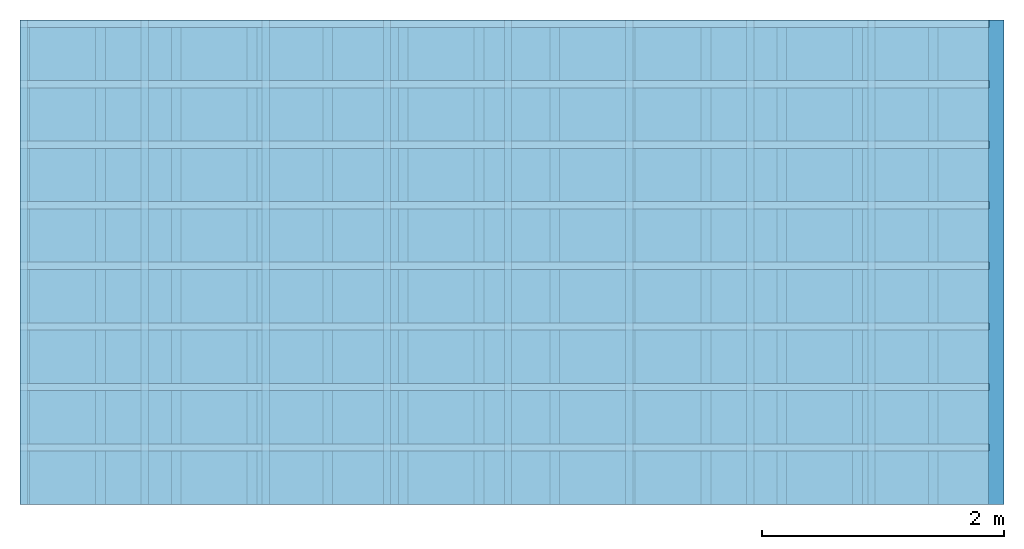
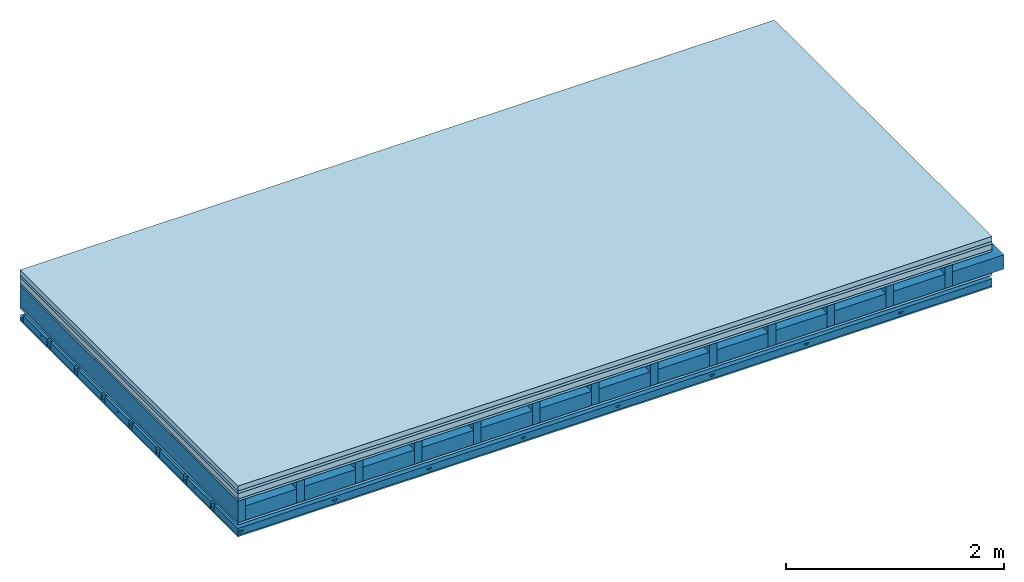
# One storey: 6 plates, 5 members, 1 element without a shape of its own.
"""IFC4 building model written with IfcOpenShell, lengths in metres."""

from ifc_helpers import new_model, si_unit, derived_unit, direction, frame, frame_2d, origin, origin_with_axes, place, context, project, spatial, polyline, rectangle, outline, extrude, material, layer, layer_set, type_object, element, aggregate, save


model = new_model("IFC4")

# Units and contexts
plan_context = context("Plan", 3, precision=1e-05, world=origin(), true_north=direction((0.0, 1.0)))
model_context = context("Model", 3, precision=1e-05, world=origin(), true_north=direction((0.0, 1.0)))
ifc_project = project(units=[si_unit("LENGTHUNIT", "METRE"), derived_unit("SOUNDPRESSUREUNIT", [(si_unit("PRESSUREUNIT", "PASCAL", prefix="MICRO"), 0)]), si_unit("ENERGYUNIT", "JOULE", prefix="MEGA"), si_unit("MASSUNIT", "GRAM", prefix="KILO"), derived_unit("THERMALTRANSMITTANCEUNIT", [(si_unit("POWERUNIT", "WATT"), 1), (si_unit("AREAUNIT", "SQUARE_METRE"), -1), (si_unit("THERMODYNAMICTEMPERATUREUNIT", "KELVIN"), -1)]), derived_unit("AREADENSITYUNIT", [(si_unit("MASSUNIT", "GRAM", prefix="KILO"), 1), (si_unit("AREAUNIT", "SQUARE_METRE"), -1)]), derived_unit("USERDEFINED", [(si_unit("ENERGYUNIT", "JOULE", prefix="MEGA"), 1), (si_unit("AREAUNIT", "SQUARE_METRE"), -1)])], contexts=[plan_context, model_context])

# Site, building, storey
site = spatial("IfcSite", under=ifc_project)
building_placement = place(None, origin())
building = spatial("IfcBuilding", under=site, at=building_placement)
storey_placement = place(building_placement, origin())
storey = spatial("IfcBuildingStorey", under=building, at=storey_placement)

# Slab, members, plates
ifc_material_1 = material(Category="04.005")
ifc_layer_1 = layer(ifc_material_1, 0.055, Name="On-material")
ifc_material_2 = material()
ifc_layer_2 = layer(ifc_material_2, 0.03, Name="Impact sound insulation")
ifc_material_3 = material(Name="Cement panels, glued on sub-floor", Category="02.007")
ifc_layer_3 = layer(ifc_material_3, 0.06, Name="on Supporting structure")
ifc_material_4 = material(Category="07.001")
ifc_layer_4 = layer(ifc_material_4, 0.025, Name="Sub-floor")
ifc_material_5 = material(Name="Rigid, of the art")
ifc_layer_5 = layer(ifc_material_5, 0.0, Name="Bond")
ifc_layer_6 = layer(None, 0.24, Name="Supporting structure")
ifc_layer_7 = layer(ifc_material_5, 0.0, Name="Bond")
ifc_layer_8 = layer(ifc_material_4, 0.025, Name="Lower layer 1")
ifc_layer_9 = layer(None, 0.093, Name="Coupling")
ifc_layer_10 = layer(None, 0.027, Name="Battens / profiles")
ifc_material_6 = material(Name="Plasterboard type A", Category="03.008")
ifc_layer_11 = layer(ifc_material_6, 0.015, Name="Ceiling covering 1st layer")
ifc_material_7 = material(Name="joints", Category="04.017")
ifc_layer_12 = layer(ifc_material_7, 0.0, Name="Surface / treatment")
ifc_layer_set = layer_set([ifc_layer_1, ifc_layer_2, ifc_layer_3, ifc_layer_4, ifc_layer_5, ifc_layer_6, ifc_layer_7, ifc_layer_8, ifc_layer_9, ifc_layer_10, ifc_layer_11, ifc_layer_12])
slab_type = type_object("IfcSlabType", Name="A0525", PredefinedType="NOTDEFINED", material=ifc_layer_set)
slab_placement = place(None, frame((0.0, 0.0, 0.0), z_axis=(0.0, 0.0, -1.0), x_axis=(1.0, 0.0, 0.0)))
slab = element("IfcSlab", 1, at=slab_placement, inside=storey, type_object=slab_type, material=ifc_layer_set, Name="Slab #1")
ifc_material_8 = material()
member_1_placement = place(slab_placement, origin())
member_1 = element("IfcMember", 2, at=member_1_placement, material=ifc_material_8, Name="Supporting structure", context=plan_context, shape_type="SweptSolid", body=[
    extrude(rectangle(XDim=0.08, YDim=0.24, at=frame_2d((0.04, 0.12), x_axis=(1.0, 0.0))), frame((0.0, 4.0, 0.17), z_axis=(0.0, -1.0, 0.0), x_axis=(1.0, 0.0, 0.0)), (0.0, 0.0, 1.0), 4.0),
    extrude(rectangle(XDim=0.08, YDim=0.24, at=frame_2d((0.04, 0.12), x_axis=(1.0, 0.0))), frame((0.625, 4.0, 0.17), z_axis=(0.0, -1.0, 0.0), x_axis=(1.0, 0.0, 0.0)), (0.0, 0.0, 1.0), 4.0),
    extrude(rectangle(XDim=0.08, YDim=0.24, at=frame_2d((0.04, 0.12), x_axis=(1.0, 0.0))), frame((1.25, 4.0, 0.17), z_axis=(0.0, -1.0, 0.0), x_axis=(1.0, 0.0, 0.0)), (0.0, 0.0, 1.0), 4.0),
    extrude(rectangle(XDim=0.08, YDim=0.24, at=frame_2d((0.04, 0.12), x_axis=(1.0, 0.0))), frame((1.875, 4.0, 0.17), z_axis=(0.0, -1.0, 0.0), x_axis=(1.0, 0.0, 0.0)), (0.0, 0.0, 1.0), 4.0),
    extrude(rectangle(XDim=0.08, YDim=0.24, at=frame_2d((0.04, 0.12), x_axis=(1.0, 0.0))), frame((2.5, 4.0, 0.17), z_axis=(0.0, -1.0, 0.0), x_axis=(1.0, 0.0, 0.0)), (0.0, 0.0, 1.0), 4.0),
    extrude(rectangle(XDim=0.08, YDim=0.24, at=frame_2d((0.04, 0.12), x_axis=(1.0, 0.0))), frame((3.125, 4.0, 0.17), z_axis=(0.0, -1.0, 0.0), x_axis=(1.0, 0.0, 0.0)), (0.0, 0.0, 1.0), 4.0),
    extrude(rectangle(XDim=0.08, YDim=0.24, at=frame_2d((0.04, 0.12), x_axis=(1.0, 0.0))), frame((3.75, 4.0, 0.17), z_axis=(0.0, -1.0, 0.0), x_axis=(1.0, 0.0, 0.0)), (0.0, 0.0, 1.0), 4.0),
    extrude(rectangle(XDim=0.08, YDim=0.24, at=frame_2d((0.04, 0.12), x_axis=(1.0, 0.0))), frame((4.375, 4.0, 0.17), z_axis=(0.0, -1.0, 0.0), x_axis=(1.0, 0.0, 0.0)), (0.0, 0.0, 1.0), 4.0),
    extrude(rectangle(XDim=0.08, YDim=0.24, at=frame_2d((0.04, 0.12), x_axis=(1.0, 0.0))), frame((5.0, 4.0, 0.17), z_axis=(0.0, -1.0, 0.0), x_axis=(1.0, 0.0, 0.0)), (0.0, 0.0, 1.0), 4.0),
    extrude(rectangle(XDim=0.08, YDim=0.24, at=frame_2d((0.04, 0.12), x_axis=(1.0, 0.0))), frame((5.625, 4.0, 0.17), z_axis=(0.0, -1.0, 0.0), x_axis=(1.0, 0.0, 0.0)), (0.0, 0.0, 1.0), 4.0),
    extrude(rectangle(XDim=0.08, YDim=0.24, at=frame_2d((0.04, 0.12), x_axis=(1.0, 0.0))), frame((6.25, 4.0, 0.17), z_axis=(0.0, -1.0, 0.0), x_axis=(1.0, 0.0, 0.0)), (0.0, 0.0, 1.0), 4.0),
    extrude(rectangle(XDim=0.08, YDim=0.24, at=frame_2d((0.04, 0.12), x_axis=(1.0, 0.0))), frame((6.875, 4.0, 0.17), z_axis=(0.0, -1.0, 0.0), x_axis=(1.0, 0.0, 0.0)), (0.0, 0.0, 1.0), 4.0),
    extrude(rectangle(XDim=0.08, YDim=0.24, at=frame_2d((0.04, 0.12), x_axis=(1.0, 0.0))), frame((7.5, 4.0, 0.17), z_axis=(0.0, -1.0, 0.0), x_axis=(1.0, 0.0, 0.0)), (0.0, 0.0, 1.0), 4.0),
])
ifc_material_9 = material()
member_2_placement = place(slab_placement, origin())
member_2 = element("IfcMember", 3, at=member_2_placement, material=ifc_material_9, Name="Cavity", context=plan_context, shape_type="SweptSolid", body=[
    extrude(rectangle(XDim=0.545, YDim=0.16, at=frame_2d((0.2725, 0.08), x_axis=(1.0, 0.0))), frame((0.08, 4.0, 0.25), z_axis=(0.0, -1.0, 0.0), x_axis=(1.0, 0.0, 0.0)), (0.0, 0.0, 1.0), 4.0),
    extrude(rectangle(XDim=0.545, YDim=0.16, at=frame_2d((0.2725, 0.08), x_axis=(1.0, 0.0))), frame((0.705, 4.0, 0.25), z_axis=(0.0, -1.0, 0.0), x_axis=(1.0, 0.0, 0.0)), (0.0, 0.0, 1.0), 4.0),
    extrude(rectangle(XDim=0.545, YDim=0.16, at=frame_2d((0.2725, 0.08), x_axis=(1.0, 0.0))), frame((1.33, 4.0, 0.25), z_axis=(0.0, -1.0, 0.0), x_axis=(1.0, 0.0, 0.0)), (0.0, 0.0, 1.0), 4.0),
    extrude(rectangle(XDim=0.545, YDim=0.16, at=frame_2d((0.2725, 0.08), x_axis=(1.0, 0.0))), frame((1.955, 4.0, 0.25), z_axis=(0.0, -1.0, 0.0), x_axis=(1.0, 0.0, 0.0)), (0.0, 0.0, 1.0), 4.0),
    extrude(rectangle(XDim=0.545, YDim=0.16, at=frame_2d((0.2725, 0.08), x_axis=(1.0, 0.0))), frame((2.58, 4.0, 0.25), z_axis=(0.0, -1.0, 0.0), x_axis=(1.0, 0.0, 0.0)), (0.0, 0.0, 1.0), 4.0),
    extrude(rectangle(XDim=0.545, YDim=0.16, at=frame_2d((0.2725, 0.08), x_axis=(1.0, 0.0))), frame((3.205, 4.0, 0.25), z_axis=(0.0, -1.0, 0.0), x_axis=(1.0, 0.0, 0.0)), (0.0, 0.0, 1.0), 4.0),
    extrude(rectangle(XDim=0.545, YDim=0.16, at=frame_2d((0.2725, 0.08), x_axis=(1.0, 0.0))), frame((3.83, 4.0, 0.25), z_axis=(0.0, -1.0, 0.0), x_axis=(1.0, 0.0, 0.0)), (0.0, 0.0, 1.0), 4.0),
    extrude(rectangle(XDim=0.545, YDim=0.16, at=frame_2d((0.2725, 0.08), x_axis=(1.0, 0.0))), frame((4.455, 4.0, 0.25), z_axis=(0.0, -1.0, 0.0), x_axis=(1.0, 0.0, 0.0)), (0.0, 0.0, 1.0), 4.0),
    extrude(rectangle(XDim=0.545, YDim=0.16, at=frame_2d((0.2725, 0.08), x_axis=(1.0, 0.0))), frame((5.08, 4.0, 0.25), z_axis=(0.0, -1.0, 0.0), x_axis=(1.0, 0.0, 0.0)), (0.0, 0.0, 1.0), 4.0),
    extrude(rectangle(XDim=0.545, YDim=0.16, at=frame_2d((0.2725, 0.08), x_axis=(1.0, 0.0))), frame((5.705, 4.0, 0.25), z_axis=(0.0, -1.0, 0.0), x_axis=(1.0, 0.0, 0.0)), (0.0, 0.0, 1.0), 4.0),
    extrude(rectangle(XDim=0.545, YDim=0.16, at=frame_2d((0.2725, 0.08), x_axis=(1.0, 0.0))), frame((6.33, 4.0, 0.25), z_axis=(0.0, -1.0, 0.0), x_axis=(1.0, 0.0, 0.0)), (0.0, 0.0, 1.0), 4.0),
    extrude(rectangle(XDim=0.545, YDim=0.16, at=frame_2d((0.2725, 0.08), x_axis=(1.0, 0.0))), frame((6.955, 4.0, 0.25), z_axis=(0.0, -1.0, 0.0), x_axis=(1.0, 0.0, 0.0)), (0.0, 0.0, 1.0), 4.0),
    extrude(rectangle(XDim=0.545, YDim=0.16, at=frame_2d((0.2725, 0.08), x_axis=(1.0, 0.0))), frame((7.58, 4.0, 0.25), z_axis=(0.0, -1.0, 0.0), x_axis=(1.0, 0.0, 0.0)), (0.0, 0.0, 1.0), 4.0),
])
ifc_material_10 = material()
member_3_placement = place(slab_placement, origin())
member_3 = element("IfcMember", 4, at=member_3_placement, material=ifc_material_10, Name="Coupling", context=plan_context, shape_type="SweptSolid", body=[
    extrude(outline(polyline([(0.0, 0.0), (0.06, 0.0), (0.04, 0.02), (0.02, 0.02), (0.0, 0.0)])), frame((0.0, 4.0, 0.508), z_axis=(0.0, -1.0, 0.0), x_axis=(1.0, 0.0, 0.0)), (0.0, 0.0, 1.0), 4.0),
    extrude(outline(polyline([(0.0, 0.0), (0.06, 0.0), (0.04, 0.02), (0.02, 0.02), (0.0, 0.0)])), frame((1.0, 4.0, 0.508), z_axis=(0.0, -1.0, 0.0), x_axis=(1.0, 0.0, 0.0)), (0.0, 0.0, 1.0), 4.0),
    extrude(outline(polyline([(0.0, 0.0), (0.06, 0.0), (0.04, 0.02), (0.02, 0.02), (0.0, 0.0)])), frame((2.0, 4.0, 0.508), z_axis=(0.0, -1.0, 0.0), x_axis=(1.0, 0.0, 0.0)), (0.0, 0.0, 1.0), 4.0),
    extrude(outline(polyline([(0.0, 0.0), (0.06, 0.0), (0.04, 0.02), (0.02, 0.02), (0.0, 0.0)])), frame((3.0, 4.0, 0.508), z_axis=(0.0, -1.0, 0.0), x_axis=(1.0, 0.0, 0.0)), (0.0, 0.0, 1.0), 4.0),
    extrude(outline(polyline([(0.0, 0.0), (0.06, 0.0), (0.04, 0.02), (0.02, 0.02), (0.0, 0.0)])), frame((4.0, 4.0, 0.508), z_axis=(0.0, -1.0, 0.0), x_axis=(1.0, 0.0, 0.0)), (0.0, 0.0, 1.0), 4.0),
    extrude(outline(polyline([(0.0, 0.0), (0.06, 0.0), (0.04, 0.02), (0.02, 0.02), (0.0, 0.0)])), frame((5.0, 4.0, 0.508), z_axis=(0.0, -1.0, 0.0), x_axis=(1.0, 0.0, 0.0)), (0.0, 0.0, 1.0), 4.0),
    extrude(outline(polyline([(0.0, 0.0), (0.06, 0.0), (0.04, 0.02), (0.02, 0.02), (0.0, 0.0)])), frame((6.0, 4.0, 0.508), z_axis=(0.0, -1.0, 0.0), x_axis=(1.0, 0.0, 0.0)), (0.0, 0.0, 1.0), 4.0),
    extrude(outline(polyline([(0.0, 0.0), (0.06, 0.0), (0.04, 0.02), (0.02, 0.02), (0.0, 0.0)])), frame((7.0, 4.0, 0.508), z_axis=(0.0, -1.0, 0.0), x_axis=(1.0, 0.0, 0.0)), (0.0, 0.0, 1.0), 4.0),
])
ifc_material_11 = material()
member_4_placement = place(slab_placement, origin())
member_4 = element("IfcMember", 5, at=member_4_placement, material=ifc_material_11, Name="Battens / profiles", context=plan_context, shape_type="SweptSolid", body=[
    extrude(rectangle(XDim=0.06, YDim=0.027, at=frame_2d((0.03, 0.0135), x_axis=(1.0, 0.0))), frame((0.0, 0.0, 0.528), z_axis=(1.0, 0.0, 0.0), x_axis=(0.0, 1.0, 0.0)), (0.0, 0.0, 1.0), 8.0),
    extrude(rectangle(XDim=0.06, YDim=0.027, at=frame_2d((0.03, 0.0135), x_axis=(1.0, 0.0))), frame((0.0, 0.5, 0.528), z_axis=(1.0, 0.0, 0.0), x_axis=(0.0, 1.0, 0.0)), (0.0, 0.0, 1.0), 8.0),
    extrude(rectangle(XDim=0.06, YDim=0.027, at=frame_2d((0.03, 0.0135), x_axis=(1.0, 0.0))), frame((0.0, 1.0, 0.528), z_axis=(1.0, 0.0, 0.0), x_axis=(0.0, 1.0, 0.0)), (0.0, 0.0, 1.0), 8.0),
    extrude(rectangle(XDim=0.06, YDim=0.027, at=frame_2d((0.03, 0.0135), x_axis=(1.0, 0.0))), frame((0.0, 1.5, 0.528), z_axis=(1.0, 0.0, 0.0), x_axis=(0.0, 1.0, 0.0)), (0.0, 0.0, 1.0), 8.0),
    extrude(rectangle(XDim=0.06, YDim=0.027, at=frame_2d((0.03, 0.0135), x_axis=(1.0, 0.0))), frame((0.0, 2.0, 0.528), z_axis=(1.0, 0.0, 0.0), x_axis=(0.0, 1.0, 0.0)), (0.0, 0.0, 1.0), 8.0),
    extrude(rectangle(XDim=0.06, YDim=0.027, at=frame_2d((0.03, 0.0135), x_axis=(1.0, 0.0))), frame((0.0, 2.5, 0.528), z_axis=(1.0, 0.0, 0.0), x_axis=(0.0, 1.0, 0.0)), (0.0, 0.0, 1.0), 8.0),
    extrude(rectangle(XDim=0.06, YDim=0.027, at=frame_2d((0.03, 0.0135), x_axis=(1.0, 0.0))), frame((0.0, 3.0, 0.528), z_axis=(1.0, 0.0, 0.0), x_axis=(0.0, 1.0, 0.0)), (0.0, 0.0, 1.0), 8.0),
    extrude(rectangle(XDim=0.06, YDim=0.027, at=frame_2d((0.03, 0.0135), x_axis=(1.0, 0.0))), frame((0.0, 3.5, 0.528), z_axis=(1.0, 0.0, 0.0), x_axis=(0.0, 1.0, 0.0)), (0.0, 0.0, 1.0), 8.0),
])
member_5_placement = place(slab_placement, origin())
member_5 = element("IfcMember", 6, at=member_5_placement, material=ifc_material_9, Name="Cavity", context=plan_context, shape_type="SweptSolid", body=[
    extrude(rectangle(XDim=0.44, YDim=0.08, at=frame_2d((0.22, 0.04), x_axis=(1.0, 0.0))), frame((0.0, 0.06, 0.475), z_axis=(1.0, 0.0, 0.0), x_axis=(0.0, 1.0, 0.0)), (0.0, 0.0, 1.0), 8.0),
    extrude(rectangle(XDim=0.44, YDim=0.08, at=frame_2d((0.22, 0.04), x_axis=(1.0, 0.0))), frame((0.0, 0.56, 0.475), z_axis=(1.0, 0.0, 0.0), x_axis=(0.0, 1.0, 0.0)), (0.0, 0.0, 1.0), 8.0),
    extrude(rectangle(XDim=0.44, YDim=0.08, at=frame_2d((0.22, 0.04), x_axis=(1.0, 0.0))), frame((0.0, 1.06, 0.475), z_axis=(1.0, 0.0, 0.0), x_axis=(0.0, 1.0, 0.0)), (0.0, 0.0, 1.0), 8.0),
    extrude(rectangle(XDim=0.44, YDim=0.08, at=frame_2d((0.22, 0.04), x_axis=(1.0, 0.0))), frame((0.0, 1.56, 0.475), z_axis=(1.0, 0.0, 0.0), x_axis=(0.0, 1.0, 0.0)), (0.0, 0.0, 1.0), 8.0),
    extrude(rectangle(XDim=0.44, YDim=0.08, at=frame_2d((0.22, 0.04), x_axis=(1.0, 0.0))), frame((0.0, 2.06, 0.475), z_axis=(1.0, 0.0, 0.0), x_axis=(0.0, 1.0, 0.0)), (0.0, 0.0, 1.0), 8.0),
    extrude(rectangle(XDim=0.44, YDim=0.08, at=frame_2d((0.22, 0.04), x_axis=(1.0, 0.0))), frame((0.0, 2.56, 0.475), z_axis=(1.0, 0.0, 0.0), x_axis=(0.0, 1.0, 0.0)), (0.0, 0.0, 1.0), 8.0),
    extrude(rectangle(XDim=0.44, YDim=0.08, at=frame_2d((0.22, 0.04), x_axis=(1.0, 0.0))), frame((0.0, 3.06, 0.475), z_axis=(1.0, 0.0, 0.0), x_axis=(0.0, 1.0, 0.0)), (0.0, 0.0, 1.0), 8.0),
    extrude(rectangle(XDim=0.44, YDim=0.08, at=frame_2d((0.22, 0.04), x_axis=(1.0, 0.0))), frame((0.0, 3.56, 0.475), z_axis=(1.0, 0.0, 0.0), x_axis=(0.0, 1.0, 0.0)), (0.0, 0.0, 1.0), 8.0),
])
plate_1_placement = place(slab_placement, origin())
plate_1 = element("IfcPlate", 7, at=plate_1_placement, material=ifc_material_1, Name="On-material", context=plan_context, shape_type="SweptSolid", body=[
    extrude(rectangle(XDim=8.0, YDim=4.0, at=frame_2d((4.0, 2.0), x_axis=(1.0, 0.0))), origin_with_axes(), (0.0, 0.0, 1.0), 0.055),
])
plate_2_placement = place(slab_placement, origin())
plate_2 = element("IfcPlate", 8, at=plate_2_placement, material=ifc_material_2, Name="Impact sound insulation", context=plan_context, shape_type="SweptSolid", body=[
    extrude(rectangle(XDim=8.0, YDim=4.0, at=frame_2d((4.0, 2.0), x_axis=(1.0, 0.0))), frame((0.0, 0.0, 0.055), z_axis=(0.0, 0.0, 1.0), x_axis=(1.0, 0.0, 0.0)), (0.0, 0.0, 1.0), 0.03),
])
plate_3_placement = place(slab_placement, origin())
plate_3 = element("IfcPlate", 9, at=plate_3_placement, material=ifc_material_3, Name="on Supporting structure", context=plan_context, shape_type="SweptSolid", body=[
    extrude(rectangle(XDim=8.0, YDim=4.0, at=frame_2d((4.0, 2.0), x_axis=(1.0, 0.0))), frame((0.0, 0.0, 0.085), z_axis=(0.0, 0.0, 1.0), x_axis=(1.0, 0.0, 0.0)), (0.0, 0.0, 1.0), 0.06),
])
plate_4_placement = place(slab_placement, origin())
plate_4 = element("IfcPlate", 10, at=plate_4_placement, material=ifc_material_4, Name="Sub-floor", context=plan_context, shape_type="SweptSolid", body=[
    extrude(rectangle(XDim=8.0, YDim=4.0, at=frame_2d((4.0, 2.0), x_axis=(1.0, 0.0))), frame((0.0, 0.0, 0.145), z_axis=(0.0, 0.0, 1.0), x_axis=(1.0, 0.0, 0.0)), (0.0, 0.0, 1.0), 0.025),
])
plate_5_placement = place(slab_placement, origin())
plate_5 = element("IfcPlate", 11, at=plate_5_placement, material=ifc_material_4, Name="Lower layer 1", context=plan_context, shape_type="SweptSolid", body=[
    extrude(rectangle(XDim=8.0, YDim=4.0, at=frame_2d((4.0, 2.0), x_axis=(1.0, 0.0))), frame((0.0, 0.0, 0.41), z_axis=(0.0, 0.0, 1.0), x_axis=(1.0, 0.0, 0.0)), (0.0, 0.0, 1.0), 0.025),
])
plate_6_placement = place(slab_placement, origin())
plate_6 = element("IfcPlate", 12, at=plate_6_placement, material=ifc_material_6, Name="Ceiling covering 1st layer", context=plan_context, shape_type="SweptSolid", body=[
    extrude(rectangle(XDim=8.0, YDim=4.0, at=frame_2d((4.0, 2.0), x_axis=(1.0, 0.0))), frame((0.0, 0.0, 0.555), z_axis=(0.0, 0.0, 1.0), x_axis=(1.0, 0.0, 0.0)), (0.0, 0.0, 1.0), 0.015),
])
aggregate(slab, [plate_1, plate_2, plate_3, plate_4, member_1, member_2, plate_5, member_3, member_4, member_5, plate_6])

save(model, "model.ifc")
